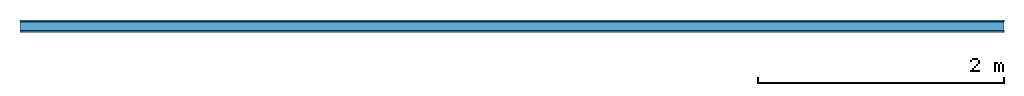
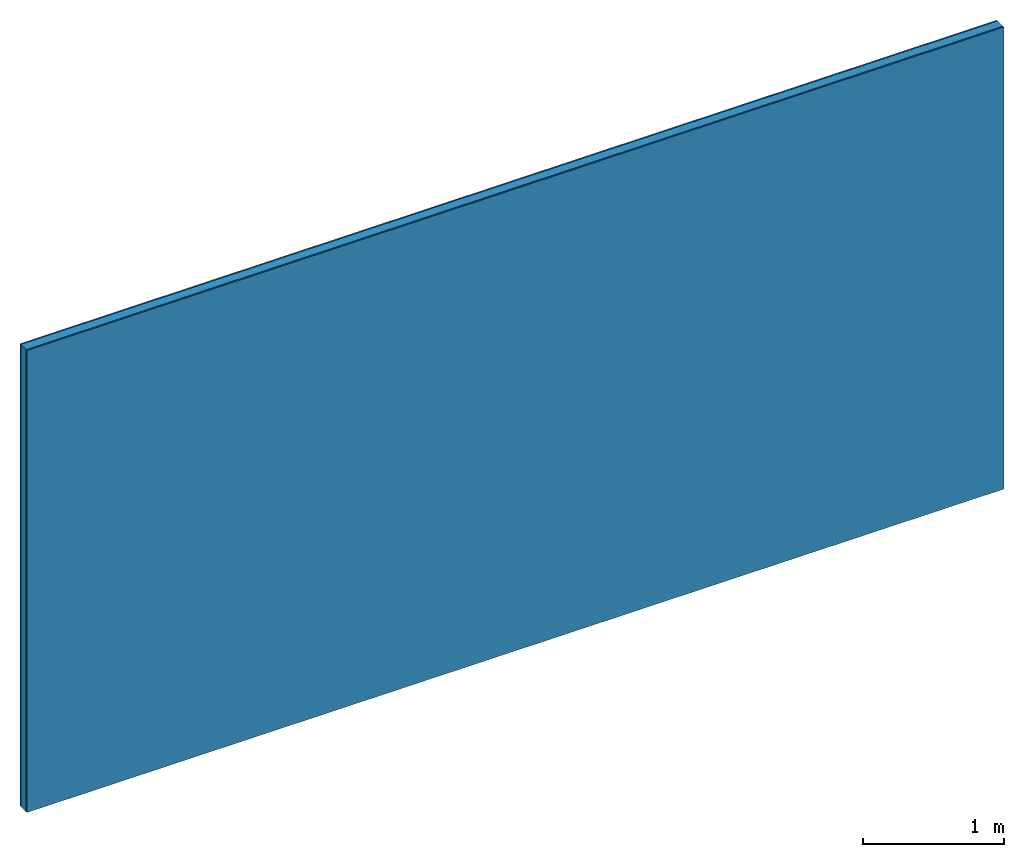
# One storey: 2 plates, 1 member, 1 element without a shape of its own.
"""IFC4 building model written with IfcOpenShell, lengths in metres."""

from ifc_helpers import new_model, si_unit, derived_unit, direction, frame, frame_2d, origin, origin_with_axes, place, context, project, spatial, rectangle, extrude, material, layer, layer_set, type_object, element, aggregate, save


model = new_model("IFC4")

# Units and contexts
plan_context = context("Plan", 3, precision=1e-05, world=origin(), true_north=direction((0.0, 1.0)))
model_context = context("Model", 3, precision=1e-05, world=origin(), true_north=direction((0.0, 1.0)))
ifc_project = project(units=[si_unit("LENGTHUNIT", "METRE"), derived_unit("SOUNDPRESSUREUNIT", [(si_unit("PRESSUREUNIT", "PASCAL", prefix="MICRO"), 0)]), si_unit("ENERGYUNIT", "JOULE", prefix="MEGA"), si_unit("MASSUNIT", "GRAM", prefix="KILO"), derived_unit("THERMALTRANSMITTANCEUNIT", [(si_unit("POWERUNIT", "WATT"), 1), (si_unit("AREAUNIT", "SQUARE_METRE"), -1), (si_unit("THERMODYNAMICTEMPERATUREUNIT", "KELVIN"), -1)]), derived_unit("AREADENSITYUNIT", [(si_unit("MASSUNIT", "GRAM", prefix="KILO"), 1), (si_unit("AREAUNIT", "SQUARE_METRE"), -1)]), derived_unit("USERDEFINED", [(si_unit("ENERGYUNIT", "JOULE", prefix="MEGA"), 1), (si_unit("AREAUNIT", "SQUARE_METRE"), -1)])], contexts=[plan_context, model_context])

# Site, building, storey
site = spatial("IfcSite", under=ifc_project)
building_placement = place(None, origin())
building = spatial("IfcBuilding", under=site, at=building_placement)
storey_placement = place(building_placement, origin())
storey = spatial("IfcBuildingStorey", under=building, at=storey_placement)

# Wall, member, plates
ifc_material_1 = material(Name="joints", Category="04.017")
ifc_layer_1 = layer(ifc_material_1, 0.0, Name="Surface")
ifc_material_2 = material(Name="Rigidur H", Category="03.007")
ifc_layer_2 = layer(ifc_material_2, 0.0125, Name="1st layer")
ifc_material_3 = material(Name="of the art")
ifc_layer_3 = layer(ifc_material_3, 0.0, Name="Bond")
ifc_layer_4 = layer(None, 0.075, Name="Support")
ifc_layer_5 = layer(ifc_material_3, 0.0, Name="Bond")
ifc_layer_6 = layer(ifc_material_2, 0.0125, Name="1st layer")
ifc_layer_7 = layer(ifc_material_1, 0.0, Name="Surface")
ifc_layer_set = layer_set([ifc_layer_1, ifc_layer_2, ifc_layer_3, ifc_layer_4, ifc_layer_5, ifc_layer_6, ifc_layer_7])
wall_type = type_object("IfcWallType", Name="C0467", PredefinedType="NOTDEFINED", material=ifc_layer_set)
wall_placement = place(None, frame((0.0, 0.0, 0.0), z_axis=(0.0, -1.0, 0.0), x_axis=(1.0, 0.0, 0.0)))
wall = element("IfcWall", 1, at=wall_placement, inside=storey, type_object=wall_type, material=ifc_layer_set, Name="Wall #1")
ifc_material_4 = material(Name="OSB")
member_placement = place(wall_placement, origin())
member = element("IfcMember", 2, at=member_placement, material=ifc_material_4, Name="Support", context=plan_context, shape_type="SweptSolid", body=[
    extrude(rectangle(XDim=1.0, YDim=0.075, at=frame_2d((0.5, 0.0375), x_axis=(1.0, 0.0))), frame((0.0, 4.0, 0.0125), z_axis=(0.0, -1.0, 0.0), x_axis=(1.0, 0.0, 0.0)), (0.0, 0.0, 1.0), 4.0),
    extrude(rectangle(XDim=1.0, YDim=0.075, at=frame_2d((0.5, 0.0375), x_axis=(1.0, 0.0))), frame((1.0, 4.0, 0.0125), z_axis=(0.0, -1.0, 0.0), x_axis=(1.0, 0.0, 0.0)), (0.0, 0.0, 1.0), 4.0),
    extrude(rectangle(XDim=1.0, YDim=0.075, at=frame_2d((0.5, 0.0375), x_axis=(1.0, 0.0))), frame((2.0, 4.0, 0.0125), z_axis=(0.0, -1.0, 0.0), x_axis=(1.0, 0.0, 0.0)), (0.0, 0.0, 1.0), 4.0),
    extrude(rectangle(XDim=1.0, YDim=0.075, at=frame_2d((0.5, 0.0375), x_axis=(1.0, 0.0))), frame((3.0, 4.0, 0.0125), z_axis=(0.0, -1.0, 0.0), x_axis=(1.0, 0.0, 0.0)), (0.0, 0.0, 1.0), 4.0),
    extrude(rectangle(XDim=1.0, YDim=0.075, at=frame_2d((0.5, 0.0375), x_axis=(1.0, 0.0))), frame((4.0, 4.0, 0.0125), z_axis=(0.0, -1.0, 0.0), x_axis=(1.0, 0.0, 0.0)), (0.0, 0.0, 1.0), 4.0),
    extrude(rectangle(XDim=1.0, YDim=0.075, at=frame_2d((0.5, 0.0375), x_axis=(1.0, 0.0))), frame((5.0, 4.0, 0.0125), z_axis=(0.0, -1.0, 0.0), x_axis=(1.0, 0.0, 0.0)), (0.0, 0.0, 1.0), 4.0),
    extrude(rectangle(XDim=1.0, YDim=0.075, at=frame_2d((0.5, 0.0375), x_axis=(1.0, 0.0))), frame((6.0, 4.0, 0.0125), z_axis=(0.0, -1.0, 0.0), x_axis=(1.0, 0.0, 0.0)), (0.0, 0.0, 1.0), 4.0),
    extrude(rectangle(XDim=1.0, YDim=0.075, at=frame_2d((0.5, 0.0375), x_axis=(1.0, 0.0))), frame((7.0, 4.0, 0.0125), z_axis=(0.0, -1.0, 0.0), x_axis=(1.0, 0.0, 0.0)), (0.0, 0.0, 1.0), 4.0),
])
plate_1_placement = place(wall_placement, origin())
plate_1 = element("IfcPlate", 3, at=plate_1_placement, material=ifc_material_2, Name="1st layer", context=plan_context, shape_type="SweptSolid", body=[
    extrude(rectangle(XDim=8.0, YDim=4.0, at=frame_2d((4.0, 2.0), x_axis=(1.0, 0.0))), origin_with_axes(), (0.0, 0.0, 1.0), 0.0125),
])
plate_2_placement = place(wall_placement, origin())
plate_2 = element("IfcPlate", 4, at=plate_2_placement, material=ifc_material_2, Name="1st layer", context=plan_context, shape_type="SweptSolid", body=[
    extrude(rectangle(XDim=8.0, YDim=4.0, at=frame_2d((4.0, 2.0), x_axis=(1.0, 0.0))), frame((0.0, 0.0, 0.0875), z_axis=(0.0, 0.0, 1.0), x_axis=(1.0, 0.0, 0.0)), (0.0, 0.0, 1.0), 0.0125),
])
aggregate(wall, [plate_1, member, plate_2])

save(model, "model.ifc")
